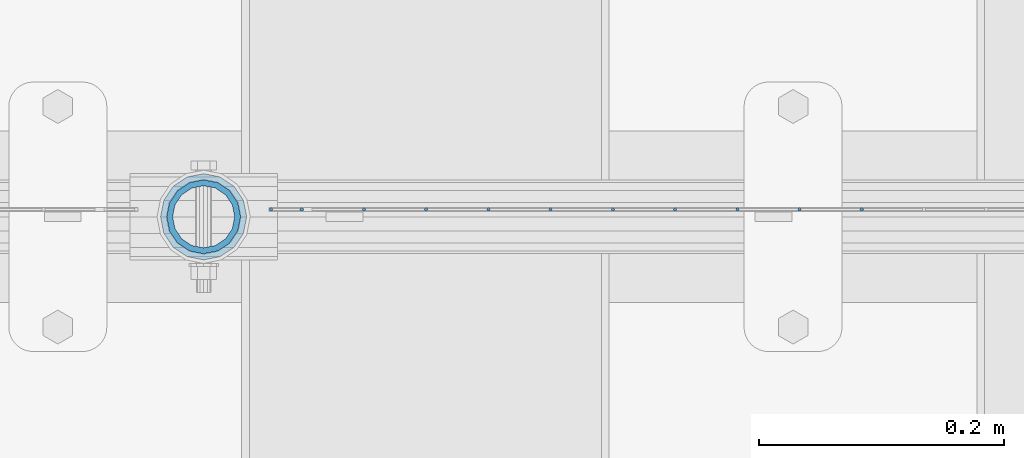
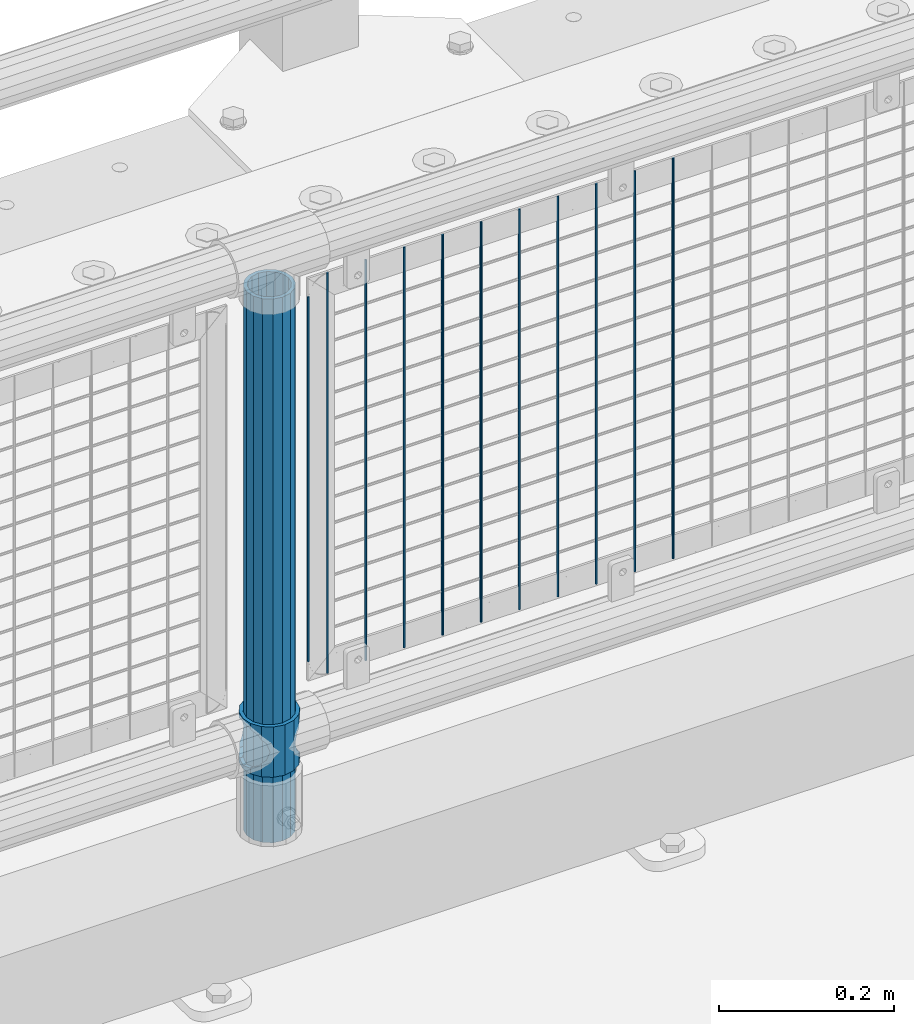
# One storey, part 84 of 242: 13 columns.
"""IFC2X3 building model written with IfcOpenShell, lengths in millimetres."""

from ifc_helpers import new_model, si_unit, frame, origin_with_axes, place, context, subcontext, project, spatial, faceted_brep, material, type_object, element, save


model = new_model("IFC2X3")

# Units and contexts
model_context = context("Model", 3, precision=1e-05, world=origin_with_axes())
body_context = subcontext(model_context, "Body", "Model", "MODEL_VIEW")
ifc_project = project(units=[si_unit("LENGTHUNIT", "METRE", prefix="MILLI"), si_unit("AREAUNIT", "SQUARE_METRE"), si_unit("VOLUMEUNIT", "CUBIC_METRE"), si_unit("MASSUNIT", "GRAM", prefix="KILO"), si_unit("TIMEUNIT", "SECOND"), si_unit("PLANEANGLEUNIT", "RADIAN"), si_unit("SOLIDANGLEUNIT", "STERADIAN"), si_unit("THERMODYNAMICTEMPERATUREUNIT", "DEGREE_CELSIUS"), si_unit("LUMINOUSINTENSITYUNIT", "LUMEN")], contexts=[model_context])

# Site, building, storey
site_placement = place(None, origin_with_axes())
site = spatial("IfcSite", under=ifc_project, at=site_placement, CompositionType="ELEMENT")
building_placement = place(site_placement, origin_with_axes())
building = spatial("IfcBuilding", under=site, at=building_placement, Name="Standard", CompositionType="ELEMENT")
storey_placement = place(building_placement, origin_with_axes())
storey = spatial("IfcBuildingStorey", under=building, at=storey_placement, Name="Undefined", CompositionType="ELEMENT", Elevation=0.0)

# Columns
ifc_material_1 = material()
column_type_1 = type_object("IfcColumnType", PredefinedType="NOTDEFINED")
column_1_placement = place(storey_placement, frame((-32031.0, -19335.5, 168.02), z_axis=(-1.0, 0.0, 0.0), x_axis=(0.0, 0.0, 1.0)))
element("IfcColumn", 1, at=column_1_placement, inside=storey, type_object=column_type_1, material=ifc_material_1, context=body_context, shape_type="Brep", body=[
    faceted_brep([(0.0, -25.3499999999985, 0.0), (0.0, -23.4203461491597, 9.70102501045403), (760.0, -23.4203461491597, 9.70102501045403), (760.0, -25.3499999999985, 0.0), (0.0, -17.9251569030785, 17.9251569030785), (760.0, -17.9251569030785, 17.9251569030785), (0.0, -9.70102501045403, 23.4203461491597), (760.0, -9.70102501045403, 23.4203461491597), (0.0, 0.0, 25.3499999999985), (760.0, 0.0, 25.3499999999985), (0.0, 9.70102501045403, 23.4203461491597), (760.0, 9.70102501045403, 23.4203461491597), (0.0, 17.9251569030785, 17.9251569030785), (760.0, 17.9251569030785, 17.9251569030785), (0.0, 23.4203461491597, 9.70102501045403), (760.0, 23.4203461491597, 9.70102501045403), (0.0, 25.3499999999985, 0.0), (760.0, 25.3499999999985, 0.0), (0.0, 23.4203461491597, -9.70102501045403), (760.0, 23.4203461491597, -9.70102501045403), (0.0, 17.9251569030785, -17.9251569030785), (760.0, 17.9251569030785, -17.9251569030785), (0.0, 9.70102501045403, -23.4203461491597), (760.0, 9.70102501045403, -23.4203461491597), (0.0, 0.0, -25.3499999999985), (760.0, 0.0, -25.3499999999985), (0.0, -9.70102501045403, -23.4203461491597), (760.0, -9.70102501045403, -23.4203461491597), (0.0, -17.9251569030785, -17.9251569030785), (760.0, -17.9251569030785, -17.9251569030785), (0.0, -23.4203461491597, -9.70102501045403), (760.0, -23.4203461491597, -9.70102501045403), (0.0, -30.1500000000015, 0.0), (0.0, -27.8549679052157, -11.5379054858058), (760.0, -27.8549679052157, -11.5379054858058), (760.0, -30.1500000000015, 0.0), (0.0, -21.3192694527752, -21.3192694527752), (760.0, -21.3192694527752, -21.3192694527752), (0.0, -11.5379054858058, -27.8549679052157), (760.0, -11.5379054858058, -27.8549679052157), (0.0, 0.0, -30.1500000000015), (760.0, 0.0, -30.1500000000015), (0.0, 11.5379054858058, -27.8549679052157), (760.0, 11.5379054858058, -27.8549679052157), (0.0, 21.3192694527752, -21.3192694527752), (760.0, 21.3192694527752, -21.3192694527752), (0.0, 27.8549679052157, -11.5379054858058), (760.0, 27.8549679052157, -11.5379054858058), (0.0, 30.1500000000015, 0.0), (760.0, 30.1500000000015, 0.0), (0.0, 27.8549679052157, 11.5379054858058), (760.0, 27.8549679052157, 11.5379054858058), (0.0, 21.3192694527752, 21.3192694527752), (760.0, 21.3192694527752, 21.3192694527752), (0.0, 11.5379054858058, 27.8549679052157), (760.0, 11.5379054858058, 27.8549679052157), (0.0, 0.0, 30.1500000000015), (760.0, 0.0, 30.1500000000015), (0.0, -11.5379054858058, 27.8549679052157), (760.0, -11.5379054858058, 27.8549679052157), (0.0, -21.3192694527752, 21.3192694527752), (760.0, -21.3192694527752, 21.3192694527752), (0.0, -27.8549679052157, 11.5379054858058), (760.0, -27.8549679052157, 11.5379054858058)], [[[0, 1, 2, 3]], [[1, 4, 5, 2]], [[4, 6, 7, 5]], [[6, 8, 9, 7]], [[8, 10, 11, 9]], [[10, 12, 13, 11]], [[12, 14, 15, 13]], [[14, 16, 17, 15]], [[16, 18, 19, 17]], [[18, 20, 21, 19]], [[20, 22, 23, 21]], [[22, 24, 25, 23]], [[24, 26, 27, 25]], [[26, 28, 29, 27]], [[28, 30, 31, 29]], [[30, 0, 3, 31]], [[32, 33, 34, 35]], [[33, 36, 37, 34]], [[36, 38, 39, 37]], [[38, 40, 41, 39]], [[40, 42, 43, 41]], [[42, 44, 45, 43]], [[44, 46, 47, 45]], [[46, 48, 49, 47]], [[48, 50, 51, 49]], [[50, 52, 53, 51]], [[52, 54, 55, 53]], [[54, 56, 57, 55]], [[56, 58, 59, 57]], [[58, 60, 61, 59]], [[60, 62, 63, 61]], [[62, 32, 35, 63]], [[37, 39, 41, 43, 45, 47, 49, 51, 53, 55, 57, 59, 61, 63, 35, 34], [5, 7, 9, 11, 13, 15, 17, 19, 21, 23, 25, 27, 29, 31, 3, 2]], [[62, 60, 58, 56, 54, 52, 50, 48, 46, 44, 42, 40, 38, 36, 33, 32], [30, 28, 26, 24, 22, 20, 18, 16, 14, 12, 10, 8, 6, 4, 1, 0]]]),
])
ifc_material_2 = material(Name="Misc_Undefined")
column_type_2 = type_object("IfcColumnType", PredefinedType="NOTDEFINED")
column_2_placement = place(storey_placement, frame((-32031.0, -19335.5, 263.02), z_axis=(-1.0, 0.0, 0.0), x_axis=(0.0, 0.0, 1.0)))
element("IfcColumn", 2, at=column_2_placement, inside=storey, type_object=column_type_2, material=ifc_material_2, context=body_context, shape_type="Brep", body=[
    faceted_brep([(63.1897438117172, 11.614442172282, -32.8397438117245), (63.1897438117172, 11.614442172282, -28.0397438117143), (56.6106908090114, 21.46069080901, -21.4606908090136), (56.6106908090114, 21.46069080901, -27.1226768591077), (61.9623795176744, 13.4513226476338, -32.4743655677739), (46.7644421722801, 28.0397438117179, -11.6144421722784), (46.7644421722801, 28.0397438117179, -20.0882031229849), (51.5310424080006, 24.8548033587067, -24.8548033587067), (35.1500000000015, 30.35, 0.0), (35.1499999999996, 30.3499999999985, -16.6306603983685), (23.5355578277192, 28.0397438117179, -11.6144421722784), (23.5355578277192, 28.0397438117179, -20.0882031229849), (18.7689575919987, 24.8548033587067, -24.8548033587067), (13.6893091909879, 21.46069080901, -21.4606908090136), (13.6893091909879, 21.46069080901, -27.1226768591077), (8.33762048232262, 13.4513226476338, -32.4743655677739), (7.11025618828211, 11.614442172282, -28.0397438117143), (7.11025618828211, 11.614442172282, -32.8397438117245), (4.79999999999961, 0.0, -30.3499999999985), (4.79999999999961, 0.0, -35.1500000000015), (7.11025618828211, -11.614442172282, -28.0397438117143), (7.11025618828211, -11.614442172282, -32.8397438117172), (13.6893091909879, -21.46069080901, -21.4606908090136), (13.6893091909879, -21.46069080901, -27.1226768591077), (8.33762048232484, -13.4513226476338, -32.4743655677739), (23.5355578277191, -28.0397438117179, -11.6144421722784), (23.5355578277191, -28.0397438117179, -20.0882031229921), (18.7689575919975, -24.8548033587067, -24.8548033587067), (35.1500000000015, -30.35, 0.0), (35.1499999999996, -30.3499999999985, -16.6306603983758), (46.7644421722801, -28.0397438117179, -11.6144421722784), (46.7644421722801, -28.0397438117179, -20.0882031229921), (51.5310424079973, -24.8548033587067, -24.8548033587067), (56.6106908090114, -21.46069080901, -21.4606908090136), (56.6106908090114, -21.46069080901, -27.1226768591077), (61.9623795176767, -13.4513226476338, -32.4743655677739), (63.1897438117172, -11.614442172282, -28.0397438117143), (63.1897438117172, -11.614442172282, -32.8397438117172), (65.4999999999997, 0.0, -30.3499999999985), (65.4999999999997, 0.0, -35.1500000000015), (0.0, -28.0397438117179, -11.6144421722784), (0.0, -30.3499999999985, 0.0), (0.0, -21.46069080901, -21.4606908090136), (0.0, -11.614442172282, -28.0397438117143), (0.0, 0.0, -30.3499999999985), (0.0, 11.614442172282, -28.0397438117143), (0.0, 21.46069080901, -21.4606908090136), (0.0, 28.0397438117179, -11.6144421722784), (0.0, 30.3499999999985, 0.0), (0.0, 28.0397438117179, 11.6144421722784), (23.5355578277192, 28.0397438117179, 11.614442172282), (0.0, 21.46069080901, 21.4606908090136), (13.6893091909879, 21.46069080901, 21.46069080901), (0.0, 11.614442172282, 28.0397438117143), (7.11025618828211, 11.614442172282, 28.0397438117179), (0.0, 0.0, 30.3499999999985), (4.79999999999961, 0.0, 30.3499999999985), (0.0, -11.614442172282, 28.0397438117143), (7.11025618828205, -11.614442172282, 28.0397438117179), (0.0, -21.46069080901, 21.4606908090136), (13.6893091909879, -21.46069080901, 21.46069080901), (0.0, -28.0397438117179, 11.6144421722784), (23.5355578277191, -28.0397438117179, 11.614442172282), (0.0, -32.4743655677703, 13.4513226476338), (0.0, -35.1500000000015, 0.0), (70.2999999999993, -35.1500000000015, 0.0), (70.2999999999993, -32.4743655677703, 13.4513226476338), (0.0, 13.4513226476338, -32.4743655677739), (0.0, 24.8548033587067, -24.8548033587067), (0.0, 0.0, -35.1500000000015), (0.0, -13.4513226476338, -32.4743655677739), (0.0, -24.8548033587067, -24.8548033587067), (0.0, -24.8548033587067, 24.8548033587067), (0.0, -13.4513226476338, 32.4743655677739), (0.0, 0.0, 35.1500000000015), (0.0, 13.4513226476338, 32.4743655677739), (0.0, 24.8548033587067, 24.8548033587067), (0.0, 32.4743655677703, 13.4513226476338), (0.0, 35.1500000000015, 0.0), (0.0, 32.4743655677703, -13.4513226476338), (0.0, -32.4743655677703, -13.4513226476338), (70.2999999999993, 32.4743655677703, 13.4513226476338), (70.2999999999993, 35.1500000000015, 0.0), (70.2999999999993, 32.4743655677703, -13.4513226476338), (70.2999999999993, 24.8548033587067, -24.8548033587067), (70.2999999999993, 13.4513226476338, -32.4743655677739), (70.2999999999993, 0.0, -35.1500000000015), (70.2999999999993, -13.4513226476338, -32.4743655677739), (70.2999999999993, -24.8548033587067, -24.8548033587067), (70.2999999999993, -32.4743655677703, -13.4513226476338), (70.2999999999993, 28.0397438117179, 11.6144421722784), (70.2999999999993, 21.46069080901, 21.4606908090136), (56.6106908090114, 21.46069080901, 21.46069080901), (46.7644421722801, 28.0397438117179, 11.614442172282), (70.2999999999993, 11.614442172282, 28.0397438117143), (63.1897438117172, 11.614442172282, 28.0397438117179), (70.2999999999993, 0.0, 30.3499999999985), (65.4999999999997, 0.0, 30.3499999999985), (70.2999999999993, -11.614442172282, 28.0397438117143), (63.1897438117172, -11.614442172282, 28.0397438117179), (70.2999999999993, -21.46069080901, 21.4606908090136), (56.6106908090114, -21.46069080901, 21.46069080901), (70.2999999999993, -28.0397438117179, 11.6144421722784), (46.7644421722801, -28.0397438117179, 11.614442172282), (70.2999999999993, -11.614442172282, -28.0397438117143), (70.2999999999993, 0.0, -30.3499999999985), (70.2999999999993, -21.46069080901, -21.4606908090136), (70.2999999999993, -28.0397438117179, -11.6144421722784), (70.2999999999993, -30.3499999999985, 0.0), (70.2999999999993, 24.8548033587067, 24.8548033587067), (70.2999999999993, 13.4513226476338, 32.4743655677739), (70.2999999999993, 0.0, 35.1500000000015), (70.2999999999993, -13.4513226476338, 32.4743655677739), (70.2999999999993, -24.8548033587067, 24.8548033587067), (70.2999999999993, 30.3499999999985, 0.0), (70.2999999999993, 28.0397438117179, -11.6144421722784), (70.2999999999993, 21.46069080901, -21.4606908090136), (70.2999999999993, 11.614442172282, -28.0397438117143), (61.9623795176744, 13.4513226476338, 32.4743655677703), (51.5310424080006, 24.8548033587067, 24.8548033587067), (56.6106908090114, 21.46069080901, 27.1226768591077), (65.4999999999997, 0.0, 35.1500000000015), (63.1897438117172, 11.614442172282, 32.8397438117136), (63.1897438117172, -11.614442172282, 32.8397438117172), (61.9623795176767, -13.4513226476338, 32.4743655677703), (56.6106908090114, -21.46069080901, 27.1226768591077), (51.5310424080038, -24.8548033587067, 24.8548033587067), (18.7689575919954, -24.8548033587067, 24.8548033587067), (46.7644421722801, -28.0397438117179, 20.0882031229885), (35.1499999999996, -30.3499999999985, 16.6306603983685), (23.5355578277191, -28.0397438117179, 20.0882031229885), (8.33762048232484, -13.4513226476338, 32.4743655677703), (13.6893091909879, -21.46069080901, 27.1226768591077), (4.79999999999961, 0.0, 35.1500000000015), (7.11025618828205, -11.614442172282, 32.8397438117172), (7.11025618828211, 11.614442172282, 32.8397438117136), (8.33762048232262, 13.4513226476338, 32.4743655677703), (13.6893091909879, 21.46069080901, 27.1226768591077), (18.768957592002, 24.8548033587067, 24.8548033587067), (23.5355578277192, 28.0397438117179, 20.0882031229812), (35.1499999999996, 30.3499999999985, 16.6306603983721), (46.7644421722801, 28.0397438117179, 20.0882031229812)], [[[0, 1, 2, 3, 4]], [[3, 2, 5, 6, 7]], [[6, 5, 8, 9]], [[9, 8, 10, 11]], [[12, 11, 10, 13, 14]], [[15, 14, 13, 16, 17]], [[17, 16, 18, 19]], [[19, 18, 20, 21]], [[21, 20, 22, 23, 24]], [[23, 22, 25, 26, 27]], [[26, 25, 28, 29]], [[29, 28, 30, 31]], [[32, 31, 30, 33, 34]], [[35, 34, 33, 36, 37]], [[37, 36, 38, 39]], [[39, 38, 1, 0]], [[40, 41, 28, 25]], [[42, 40, 25, 22]], [[43, 42, 22, 20]], [[44, 43, 20, 18]], [[45, 44, 18, 16]], [[46, 45, 16, 13]], [[47, 46, 13, 10]], [[48, 47, 10, 8]], [[49, 48, 8, 50]], [[51, 49, 50, 52]], [[53, 51, 52, 54]], [[55, 53, 54, 56]], [[57, 55, 56, 58]], [[59, 57, 58, 60]], [[61, 59, 60, 62]], [[41, 61, 62, 28]], [[63, 64, 65, 66]], [[67, 68, 12, 14, 15]], [[69, 67, 15, 17, 19]], [[24, 70, 69, 19, 21]], [[27, 71, 70, 24, 23]], [[63, 72, 73, 74, 75, 76, 77, 78, 79, 68, 67, 69, 70, 71, 80, 64], [40, 42, 43, 44, 45, 46, 47, 48, 49, 51, 53, 55, 57, 59, 61, 41]], [[78, 77, 81, 82]], [[79, 78, 82, 83]], [[68, 79, 83, 84, 7, 6, 9, 11, 12]], [[7, 84, 85, 4, 3]], [[4, 85, 86, 39, 0]], [[87, 88, 32, 34, 35]], [[86, 87, 35, 37, 39]], [[29, 31, 32, 88, 89, 80, 71, 27, 26]], [[64, 80, 89, 65]], [[90, 91, 92, 93]], [[91, 94, 95, 92]], [[94, 96, 97, 95]], [[96, 98, 99, 97]], [[98, 100, 101, 99]], [[100, 102, 103, 101]], [[104, 105, 38, 36]], [[106, 104, 36, 33]], [[107, 106, 33, 30]], [[108, 107, 30, 28]], [[102, 108, 28, 103]], [[88, 87, 86, 85, 84, 83, 82, 81, 109, 110, 111, 112, 113, 66, 65, 89], [100, 98, 96, 94, 91, 90, 114, 115, 116, 117, 105, 104, 106, 107, 108, 102]], [[118, 110, 109, 119, 120]], [[121, 111, 110, 118, 122]], [[112, 111, 121, 123, 124]], [[113, 112, 124, 125, 126]], [[127, 72, 63, 66, 113, 126, 128, 129, 130]], [[131, 73, 72, 127, 132]], [[133, 74, 73, 131, 134]], [[75, 74, 133, 135, 136]], [[76, 75, 136, 137, 138]], [[119, 109, 81, 77, 76, 138, 139, 140, 141]], [[92, 120, 119, 141, 93]], [[95, 122, 118, 120, 92]], [[97, 121, 122, 95]], [[99, 123, 121, 97]], [[101, 125, 124, 123, 99]], [[103, 128, 126, 125, 101]], [[28, 129, 128, 103]], [[62, 130, 129, 28]], [[60, 132, 127, 130, 62]], [[58, 134, 131, 132, 60]], [[56, 133, 134, 58]], [[54, 135, 133, 56]], [[52, 137, 136, 135, 54]], [[50, 139, 138, 137, 52]], [[8, 140, 139, 50]], [[93, 141, 140, 8]], [[114, 90, 93, 8]], [[115, 114, 8, 5]], [[116, 115, 5, 2]], [[117, 116, 2, 1]], [[105, 117, 1, 38]]]),
])
column_type_3 = type_object("IfcColumnType", Name="D3", PredefinedType="NOTDEFINED")
for number, where, z_axis, x_axis in (
    (3, (-31493.863, -19329.5, 353.02), (-1.0, 0.0, 0.0), (0.0, 0.0, 1.0)),
    (4, (-31544.656, -19329.5, 353.02), (-1.0, 0.0, 0.0), (0.0, 0.0, 1.0)),
    (5, (-31595.449, -19329.5, 353.02), (-1.0, 0.0, 0.0), (0.0, 0.0, 1.0)),
    (6, (-31646.242, -19329.5, 353.02), (-1.0, 0.0, 0.0), (0.0, 0.0, 1.0)),
    (7, (-31697.035, -19329.5, 353.02), (-1.0, 0.0, 0.0), (0.0, 0.0, 1.0)),
    (8, (-31747.828, -19329.5, 353.02), (-1.0, 0.0, 0.0), (0.0, 0.0, 1.0)),
    (9, (-31798.621, -19329.5, 353.02), (-1.0, 0.0, 0.0), (0.0, 0.0, 1.0)),
    (10, (-31849.414, -19329.5, 353.02), (-1.0, 0.0, 0.0), (0.0, 0.0, 1.0)),
    (11, (-31900.207, -19329.5, 353.02), (-1.0, 0.0, 0.0), (0.0, 0.0, 1.0)),
):
    element("IfcColumn", number, at=place(storey_placement, frame(where, z_axis=z_axis, x_axis=x_axis)), inside=storey, type_object=column_type_3, material=ifc_material_2, ObjectType="D3", context=body_context, shape_type="Brep", body=[
        faceted_brep([(0.0, -1.50000000000364, 0.0), (-3.63797880709171e-12, -0.750000000003638, -1.29903810567669), (560.0, -0.75, -1.29903810567703), (560.0, -1.5, 0.0), (0.0, 0.749999999996362, -1.29903810567669), (560.0, 0.75, -1.29903810567703), (-3.63797880709171e-12, 1.49999999999636, 0.0), (560.0, 1.5, 0.0), (0.0, 0.749999999996362, 1.29903810567669), (560.0, 0.75, 1.29903810567703), (-3.63797880709171e-12, -0.750000000003638, 1.29903810567669), (560.0, -0.75, 1.29903810567703)], [[[0, 1, 2, 3]], [[1, 4, 5, 2]], [[4, 6, 7, 5]], [[6, 8, 9, 7]], [[8, 10, 11, 9]], [[10, 0, 3, 11]], [[5, 7, 9, 11, 3, 2]], [[10, 8, 6, 4, 1, 0]]]),
    ])
column_3_placement = place(storey_placement, frame((-31976.0, -19329.5, 378.02), z_axis=(-1.0, 0.0, 0.0), x_axis=(0.0, 0.0, 1.0)))
element("IfcColumn", 12, at=column_3_placement, inside=storey, type_object=column_type_3, material=ifc_material_2, ObjectType="D3", context=body_context, shape_type="Brep", body=[
    faceted_brep([(0.0, -1.50000000000364, 0.0), (-3.63797880709171e-12, -0.750000000003638, -1.29903810567669), (510.0, -0.75, -1.29903810567703), (510.0, -1.5, 0.0), (0.0, 0.749999999996362, -1.29903810567669), (510.0, 0.75, -1.29903810567703), (-3.63797880709171e-12, 1.49999999999636, 0.0), (510.0, 1.5, 0.0), (0.0, 0.749999999996362, 1.29903810567669), (510.0, 0.75, 1.29903810567703), (-3.63797880709171e-12, -0.750000000003638, 1.29903810567669), (510.0, -0.75, 1.29903810567703)], [[[0, 1, 2, 3]], [[1, 4, 5, 2]], [[4, 6, 7, 5]], [[6, 8, 9, 7]], [[8, 10, 11, 9]], [[10, 0, 3, 11]], [[5, 7, 9, 11, 3, 2]], [[10, 8, 6, 4, 1, 0]]]),
])
column_4_placement = place(storey_placement, frame((-31951.0, -19329.5, 353.02), z_axis=(-1.0, 0.0, 0.0), x_axis=(0.0, 0.0, 1.0)))
element("IfcColumn", 13, at=column_4_placement, inside=storey, type_object=column_type_3, material=ifc_material_2, ObjectType="D3", context=body_context, shape_type="Brep", body=[
    faceted_brep([(0.0, -1.50000000000364, 0.0), (-3.63797880709171e-12, -0.750000000003638, -1.29903810567669), (560.0, -0.75, -1.29903810567703), (560.0, -1.5, 0.0), (0.0, 0.749999999996362, -1.29903810567669), (560.0, 0.75, -1.29903810567703), (-3.63797880709171e-12, 1.49999999999636, 0.0), (560.0, 1.5, 0.0), (0.0, 0.749999999996362, 1.29903810567669), (560.0, 0.75, 1.29903810567703), (-3.63797880709171e-12, -0.750000000003638, 1.29903810567669), (560.0, -0.75, 1.29903810567703)], [[[0, 1, 2, 3]], [[1, 4, 5, 2]], [[4, 6, 7, 5]], [[6, 8, 9, 7]], [[8, 10, 11, 9]], [[10, 0, 3, 11]], [[5, 7, 9, 11, 3, 2]], [[10, 8, 6, 4, 1, 0]]]),
])

save(model, "model.ifc")
